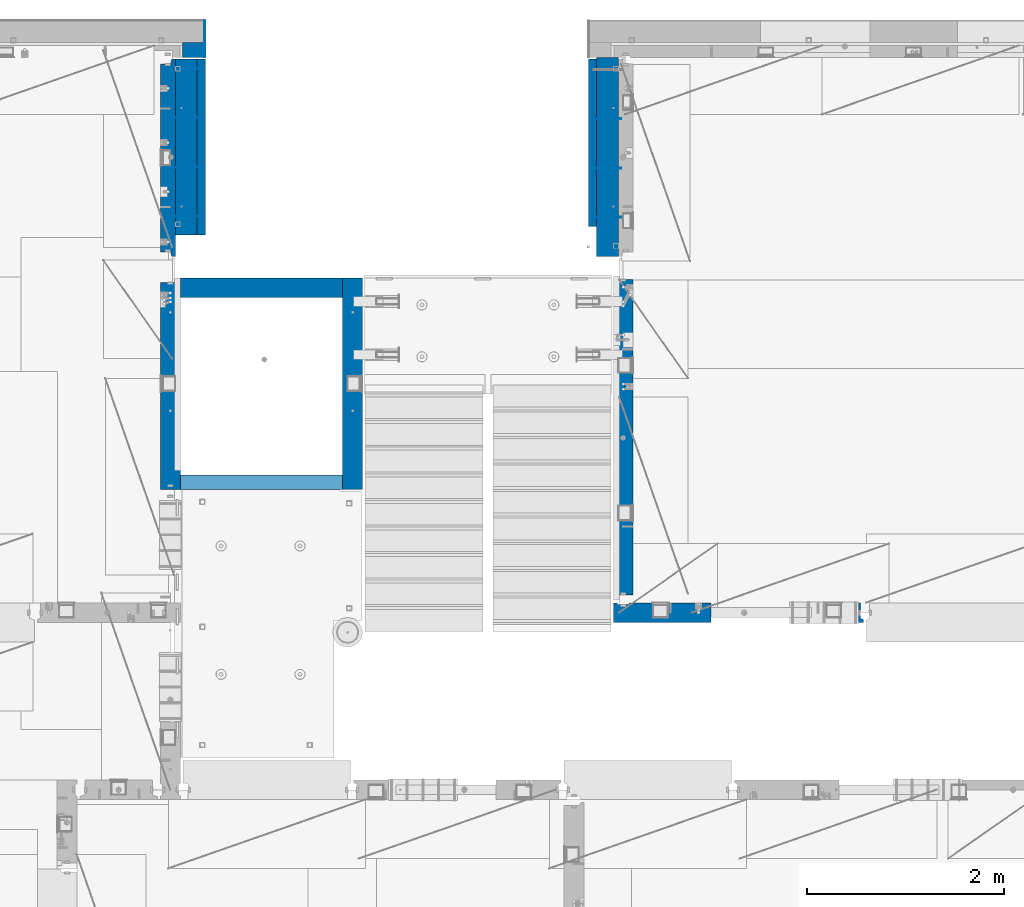
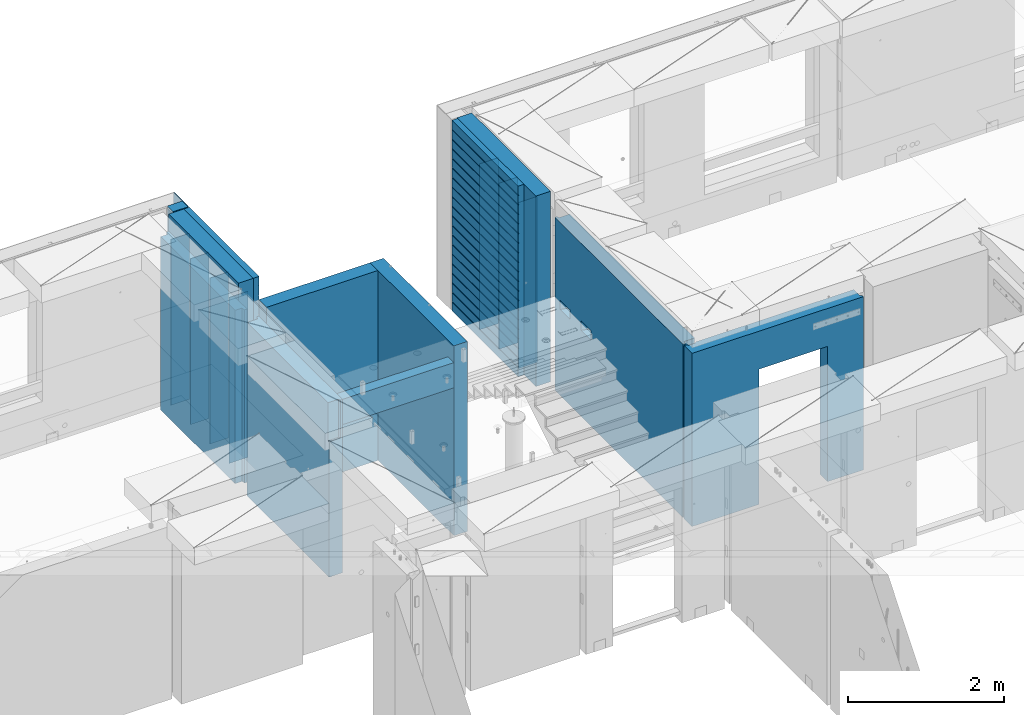
# One storey, part 227 of 334: 20 walls, 6 elements without a shape of their own.
"""IFC2X3 building model written with IfcOpenShell, lengths in millimetres."""

from ifc_helpers import new_model, si_unit, frame, origin_with_axes, place, context, subcontext, project, spatial, faceted_brep, material, type_object, element, aggregate, save


model = new_model("IFC2X3")

# Units and contexts
model_context = context("Model", 3, precision=1e-05, world=origin_with_axes())
body_context = subcontext(model_context, "Body", "Model", "MODEL_VIEW")
ifc_project = project(units=[si_unit("LENGTHUNIT", "METRE", prefix="MILLI"), si_unit("AREAUNIT", "SQUARE_METRE"), si_unit("VOLUMEUNIT", "CUBIC_METRE"), si_unit("MASSUNIT", "GRAM", prefix="KILO"), si_unit("TIMEUNIT", "SECOND"), si_unit("PLANEANGLEUNIT", "RADIAN"), si_unit("SOLIDANGLEUNIT", "STERADIAN"), si_unit("THERMODYNAMICTEMPERATUREUNIT", "DEGREE_CELSIUS"), si_unit("LUMINOUSINTENSITYUNIT", "LUMEN")], contexts=[model_context])

# Site, building, storey
site_placement = place(None, origin_with_axes())
site = spatial("IfcSite", under=ifc_project, at=site_placement, CompositionType="ELEMENT")
building_placement = place(site_placement, origin_with_axes())
building = spatial("IfcBuilding", under=site, at=building_placement, CompositionType="ELEMENT")
storey_placement = place(building_placement, origin_with_axes())
storey = spatial("IfcBuildingStorey", under=building, at=storey_placement, Name="3", CompositionType="ELEMENT", Elevation=0.0)

# Assembly, walls
assembly_1_placement = place(storey_placement, origin_with_axes())
assembly_1 = element("IfcElementAssembly", 1, at=assembly_1_placement, inside=storey, AssemblyPlace="NOTDEFINED", PredefinedType="REINFORCEMENT_UNIT")
ifc_material_1 = material(Name="Undefined")
wall_type_1 = type_object("IfcWallType", PredefinedType="NOTDEFINED")
wall_1_placement = place(assembly_1_placement, frame((22290.0, 21995.0, 89110.0), z_axis=(0.0, 0.0, 1.0), x_axis=(-1.0, 3.00000001838171e-08, 0.0)))
wall_1 = element("IfcWall", 2, at=wall_1_placement, type_object=wall_type_1, material=ifc_material_1, Name="(PD)", context=body_context, shape_type="Brep", body=[
    faceted_brep([(0.0, 5.0, -1300.0), (0.0, 5.0, 1300.0), (280.0, 5.0, 1300.0), (280.0, 5.0, -1300.0), (0.0, -5.0, 1300.0), (280.0, -5.0, 1300.0), (0.0, -5.0, -1300.0), (280.0, -5.0, -1300.0)], [[[0, 1, 2, 3]], [[1, 4, 5, 2]], [[4, 6, 7, 5]], [[6, 0, 3, 7]], [[5, 7, 3, 2]], [[6, 4, 1, 0]]]),
])
wall_2_placement = place(assembly_1_placement, frame((22290.0, 21495.0, 89110.0), z_axis=(0.0, 0.0, 1.0), x_axis=(-1.0, 3.00000001838171e-08, 0.0)))
wall_2 = element("IfcWall", 3, at=wall_2_placement, type_object=wall_type_1, material=ifc_material_1, Name="(PD)", context=body_context, shape_type="Brep", body=[
    faceted_brep([(0.0, 5.0, -1300.0), (0.0, 5.0, 1300.0), (280.0, 5.0, 1300.0), (280.0, 5.0, -1300.0), (0.0, -5.0, 1300.0), (280.0, -5.0, 1300.0), (0.0, -5.0, -1300.0), (280.0, -5.0, -1300.0)], [[[0, 1, 2, 3]], [[1, 4, 5, 2]], [[4, 6, 7, 5]], [[6, 0, 3, 7]], [[5, 7, 3, 2]], [[6, 4, 1, 0]]]),
])
wall_3_placement = place(assembly_1_placement, frame((22290.0, 20995.0, 89110.0), z_axis=(0.0, 0.0, 1.0), x_axis=(-1.0, 3.00000001838171e-08, 0.0)))
wall_3 = element("IfcWall", 4, at=wall_3_placement, type_object=wall_type_1, material=ifc_material_1, Name="(PD)", context=body_context, shape_type="Brep", body=[
    faceted_brep([(0.0, 5.0, -1300.0), (0.0, 5.0, 1300.0), (280.0, 5.0, 1300.0), (280.0, 5.0, -1300.0), (0.0, -5.0, 1300.0), (280.0, -5.0, 1300.0), (0.0, -5.0, -1300.0), (280.0, -5.0, -1300.0)], [[[0, 1, 2, 3]], [[1, 4, 5, 2]], [[4, 6, 7, 5]], [[6, 0, 3, 7]], [[5, 7, 3, 2]], [[6, 4, 1, 0]]]),
])

assembly_2_placement = place(storey_placement, origin_with_axes())
assembly_2 = element("IfcElementAssembly", 5, at=assembly_2_placement, inside=storey, Name="(PD)", AssemblyPlace="NOTDEFINED", PredefinedType="REINFORCEMENT_UNIT")
wall_4_placement = place(assembly_2_placement, frame((17730.0, 21005.0, 89115.0), z_axis=(0.0, 0.0, 1.0), x_axis=(1.0, 0.0, 0.0)))
wall_4 = element("IfcWall", 6, at=wall_4_placement, type_object=wall_type_1, material=ifc_material_1, Name="(PD)", context=body_context, shape_type="Brep", body=[
    faceted_brep([(0.0, 5.0, -1300.0), (0.0, 5.0, 1300.0), (280.0, 5.0, 1300.0), (280.0, 5.0, -1300.0), (0.0, -5.0, 1300.0), (280.0, -5.0, 1300.0), (0.0, -5.0, -1300.0), (280.0, -5.0, -1300.0)], [[[0, 1, 2, 3]], [[1, 4, 5, 2]], [[4, 6, 7, 5]], [[6, 0, 3, 7]], [[5, 7, 3, 2]], [[6, 4, 1, 0]]]),
])
wall_5_placement = place(assembly_2_placement, frame((17730.0, 21505.0, 89115.0), z_axis=(0.0, 0.0, 1.0), x_axis=(1.0, 0.0, 0.0)))
wall_5 = element("IfcWall", 7, at=wall_5_placement, type_object=wall_type_1, material=ifc_material_1, Name="(PD)", context=body_context, shape_type="Brep", body=[
    faceted_brep([(0.0, 5.0, -1300.0), (0.0, 5.0, 1300.0), (280.0, 5.0, 1300.0), (280.0, 5.0, -1300.0), (0.0, -5.0, 1300.0), (280.0, -5.0, 1300.0), (0.0, -5.0, -1300.0), (280.0, -5.0, -1300.0)], [[[0, 1, 2, 3]], [[1, 4, 5, 2]], [[4, 6, 7, 5]], [[6, 0, 3, 7]], [[5, 7, 3, 2]], [[6, 4, 1, 0]]]),
])
wall_6_placement = place(assembly_2_placement, frame((17730.0, 22005.0, 89115.0), z_axis=(0.0, 0.0, 1.0), x_axis=(1.0, 0.0, 0.0)))
wall_6 = element("IfcWall", 8, at=wall_6_placement, type_object=wall_type_1, material=ifc_material_1, Name="(PD)", context=body_context, shape_type="Brep", body=[
    faceted_brep([(0.0, 5.0, -1300.0), (0.0, 5.0, 1300.0), (280.0, 5.0, 1300.0), (280.0, 5.0, -1300.0), (0.0, -5.0, 1300.0), (280.0, -5.0, 1300.0), (0.0, -5.0, -1300.0), (280.0, -5.0, -1300.0)], [[[0, 1, 2, 3]], [[1, 4, 5, 2]], [[4, 6, 7, 5]], [[6, 0, 3, 7]], [[5, 7, 3, 2]], [[6, 4, 1, 0]]]),
])
wall_7_placement = place(assembly_2_placement, frame((17730.0, 22505.0, 89115.0), z_axis=(0.0, 0.0, 1.0), x_axis=(1.0, 0.0, 0.0)))
wall_7 = element("IfcWall", 9, at=wall_7_placement, type_object=wall_type_1, material=ifc_material_1, Name="(PD)", context=body_context, shape_type="Brep", body=[
    faceted_brep([(0.0, 5.0, -1300.0), (0.0, 5.0, 1300.0), (280.0, 5.0, 1300.0), (280.0, 5.0, -1300.0), (0.0, -5.0, 1300.0), (280.0, -5.0, 1300.0), (0.0, -5.0, -1300.0), (280.0, -5.0, -1300.0)], [[[0, 1, 2, 3]], [[1, 4, 5, 2]], [[4, 6, 7, 5]], [[6, 0, 3, 7]], [[5, 7, 3, 2]], [[6, 4, 1, 0]]]),
])

# Assembly, wall
assembly_3_placement = place(storey_placement, origin_with_axes())
assembly_3 = element("IfcElementAssembly", 10, at=assembly_3_placement, inside=storey, AssemblyPlace="NOTDEFINED", PredefinedType="REINFORCEMENT_UNIT")
ifc_material_2 = material(Name="CONCRETE/C25/30")
wall_type_2 = type_object("IfcWallType", PredefinedType="NOTDEFINED")
wall_8_placement = place(assembly_3_placement, frame((17710.0, 18214.9992663657, 89112.5), z_axis=(0.0, 0.0, 1.0), x_axis=(0.0, 1.0, 0.0)))
wall_8 = element("IfcWall", 11, at=wall_8_placement, type_object=wall_type_2, material=ifc_material_2, context=body_context, shape_type="Brep", body=[
    faceted_brep([(2120.00073363433, -57.0000000000036, 1357.5), (2120.00073363433, -57.0000000000036, -1357.5), (2120.00073363433, 100.0, -1357.5), (2120.00073363433, 100.0, 1357.5), (2165.00073363433, -70.0000000000036, 1357.5), (2165.00073363433, -70.0000000000036, -1357.5), (45.0, 100.0, 1357.5), (45.0, 100.0, 762.5), (45.0, -57.0, 762.5), (45.0, -57.0, 1357.5), (15.0, -70.0, 762.5), (15.0, 100.0, 762.5), (15.0, -70.0, 1357.5), (15.0, 100.0, -1357.5), (15.0, -100.0, -1357.5), (15.0, -100.0, 1357.5), (2165.00073363433, -100.0, -1357.5), (2165.00073363433, -100.0, 1357.5)], [[[0, 1, 2, 3]], [[4, 5, 1, 0]], [[6, 7, 8, 9]], [[10, 8, 7, 11]], [[12, 9, 8, 10]], [[11, 13, 14, 15, 12, 10]], [[15, 14, 16, 17]], [[3, 6, 9, 12, 15, 17, 4, 0]], [[13, 11, 7, 6, 3, 2]], [[16, 14, 13, 2, 1, 5]], [[17, 16, 5, 4]]]),
])

assembly_4_placement = place(storey_placement, origin_with_axes())
assembly_4 = element("IfcElementAssembly", 12, at=assembly_4_placement, inside=storey, AssemblyPlace="NOTDEFINED", PredefinedType="REINFORCEMENT_UNIT")
wall_9_placement = place(assembly_4_placement, frame((22310.0, 16980.0, 89112.5), z_axis=(0.0, 0.0, 1.0), x_axis=(1.0, 0.0, 0.0)))
wall_9 = element("IfcWall", 13, at=wall_9_placement, type_object=wall_type_2, material=ifc_material_2, context=body_context, shape_type="Brep", body=[
    faceted_brep([(890.000686645508, 100.0, 762.5), (890.000686645508, -100.0, 762.5), (890.000686645508, -100.0, -1357.5), (890.000686645508, 100.0, -1357.5), (1910.00068664551, 100.0, 762.5), (1910.00068664551, -100.0, 762.5), (1910.00068664551, 100.0, -1357.5), (1910.00068664551, -100.0, -1357.5), (-100.0, -100.0, -1357.5), (-100.0, -100.0, 1357.5), (-100.0, 100.0, 1357.5), (-100.0, 100.0, -1357.5), (2440.0, -100.0, 1357.5), (2440.0, -100.0, -1357.5), (2440.0, -70.0000000000036, -1357.5), (2440.0, -70.0000000000036, 1357.5), (2410.0, 100.0, 1357.5), (2410.0, -57.0, 1357.5), (2410.0, -57.0, -1357.5), (2410.0, 100.0, -1357.5), (65.0000000000036, 100.0, 1357.5), (52.0, 80.0, 1357.5), (-52.0, 80.0, 1357.5), (-65.0, 100.0, 1357.5), (-65.0, 100.0, -1357.5), (-52.0, 80.0, -1357.5), (52.0, 80.0, -1357.5), (65.0000000000036, 100.0, -1357.5)], [[[0, 1, 2, 3]], [[4, 5, 1, 0]], [[6, 7, 5, 4]], [[8, 9, 10, 11]], [[12, 13, 14, 15]], [[16, 17, 18, 19]], [[15, 14, 18, 17]], [[16, 20, 21, 22, 23, 10, 9, 12, 15, 17]], [[11, 10, 23, 24]], [[22, 25, 24, 23]], [[21, 26, 25, 22]], [[20, 27, 26, 21]], [[8, 11, 24, 25, 26, 27, 3, 2]], [[13, 12, 9, 8, 2, 1, 5, 7]], [[19, 18, 14, 13, 7, 6]], [[3, 27, 20, 16, 19, 6, 4, 0]]]),
])
aggregate(assembly_4, [wall_9])

assembly_5_placement = place(storey_placement, origin_with_axes())
assembly_5 = element("IfcElementAssembly", 14, at=assembly_5_placement, inside=storey, AssemblyPlace="NOTDEFINED", PredefinedType="REINFORCEMENT_UNIT")
wall_10_placement = place(assembly_5_placement, frame((22310.0, 16980.0, 89112.5), z_axis=(0.0, 0.0, 1.0), x_axis=(0.0, 1.0, 0.0)))
wall_10 = element("IfcWall", 15, at=wall_10_placement, type_object=wall_type_2, material=ifc_material_2, context=body_context, shape_type="Brep", body=[
    faceted_brep([(3059.9952678883, 0.0998642726626713, 102.5), (3259.9952678883, 0.0998642726626713, 102.5), (3259.9952678883, 0.0998642726626713, -7.5), (3059.9952678883, 0.0998642726626713, -7.5), (3034.9952678883, 100.099864272663, -7.5), (3284.9952678883, 100.099864272663, -7.5), (3034.9952678883, 100.099864272663, 137.5), (3284.9952678883, 100.099864272663, 137.5), (3420.0, 70.0, 1357.5), (3420.0, 100.0, 1357.5), (130.0, 100.0, 1357.5), (130.0, 70.0, 1357.5), (180.0, 57.0, 1357.5), (180.0, -100.0, 1357.5), (3384.99999178648, -100.000000948603, 1357.5), (3385.00000172571, 57.0000007519884, 1357.5), (130.0, 100.0, -1357.5), (130.0, 70.0, -1357.5), (180.0, 57.0, -1357.5), (180.0, -100.0, -1357.5), (3384.99999178648, -100.0, -1357.5), (3385.00000172571, 57.0000007519884, -1357.5), (3420.0, 100.0, -1357.5), (3420.0, 70.0, -1357.5), (2519.9952678883, 0.0998642726626713, 102.5), (2719.9952678883, 0.0998642726626713, 102.5), (2719.9952678883, 0.0998642726626713, -7.5), (2519.9952678883, 0.0998642726626713, -7.5), (2744.9952678883, 100.099864272663, -7.5), (2744.9952678883, 100.099864272663, 137.5), (2494.9952678883, 100.099864272663, -7.5), (2494.9952678883, 100.099864272663, 137.5)], [[[0, 1, 2, 3]], [[4, 3, 2, 5]], [[6, 0, 3, 4]], [[7, 1, 0, 6]], [[5, 2, 1, 7]], [[8, 9, 10, 11, 12, 13, 14, 15]], [[10, 16, 17, 11]], [[11, 17, 18, 12]], [[13, 12, 18, 19]], [[13, 19, 20, 14]], [[14, 20, 21, 15]], [[19, 18, 17, 16, 22, 23, 21, 20]], [[15, 21, 23, 8]], [[22, 9, 8, 23]], [[24, 25, 26, 27]], [[28, 26, 25, 29]], [[30, 27, 26, 28]], [[31, 24, 27, 30]], [[29, 25, 24, 31]], [[16, 10, 9, 22], [4, 5, 7, 6], [30, 28, 29, 31]]]),
])
aggregate(assembly_5, [wall_10])

# Wall
ifc_material_3 = material(Name="COS5gt")
wall_type_3 = type_object("IfcWallType", PredefinedType="NOTDEFINED")
wall_11_placement = place(assembly_1_placement, frame((22150.0, 20595.0, 89247.5), z_axis=(0.0, 0.0, 1.0), x_axis=(0.0, 1.0, 0.0)))
wall_11 = element("IfcWall", 16, at=wall_11_placement, type_object=wall_type_3, material=ifc_material_3, context=body_context, shape_type="Brep", body=[
    faceted_brep([(0.0, 110.0, -1492.5), (0.0, 110.0, 1492.5), (2025.0, 110.0, 1492.5), (2025.0, 110.0, -1492.5), (0.0, -110.0, 1492.5), (2025.0, -110.0, 1492.5), (0.0, -110.0, -1492.5), (2025.0, -110.0, -1492.5)], [[[0, 1, 2, 3]], [[1, 4, 5, 2]], [[4, 6, 7, 5]], [[6, 0, 3, 7]], [[5, 7, 3, 2]], [[6, 4, 1, 0]]]),
])

# Assembly, wall
assembly_6_placement = place(storey_placement, origin_with_axes())
assembly_6 = element("IfcElementAssembly", 17, at=assembly_6_placement, inside=storey, AssemblyPlace="NOTDEFINED", PredefinedType="REINFORCEMENT_UNIT")
ifc_material_4 = material()
wall_12_placement = place(assembly_6_placement, frame((17945.0, 22770.0, 89247.5), z_axis=(0.0, 0.0, 1.0), x_axis=(0.0, -1.0, 0.0)))
wall_12 = element("IfcWall", 18, at=wall_12_placement, type_object=wall_type_3, material=ifc_material_4, context=body_context, shape_type="Brep", body=[
    faceted_brep([(0.0, 110.0, -1492.5), (0.0, 110.0, 1492.5), (150.0, 110.0, 1492.5), (150.0, 110.0, -1492.5), (0.0, -110.0, 1492.5), (150.0, -110.0, 1492.5), (0.0, -110.0, -1492.5), (150.0, -110.0, -1492.5)], [[[0, 1, 2, 3]], [[1, 4, 5, 2]], [[4, 6, 7, 5]], [[6, 0, 3, 7]], [[5, 7, 3, 2]], [[6, 4, 1, 0]]]),
])

# Wall
wall_13_placement = place(assembly_2_placement, frame((17870.0, 22605.0, 89247.5), z_axis=(0.0, 0.0, 1.0), x_axis=(0.0, -1.0, 0.0)))
wall_13 = element("IfcWall", 19, at=wall_13_placement, type_object=wall_type_3, material=ifc_material_3, context=body_context, shape_type="Brep", body=[
    faceted_brep([(0.0, 110.0, -1492.5), (0.0, 110.0, 1492.5), (1790.0, 110.0, 1492.5), (1790.0, 110.0, -1492.5), (0.0, -110.0, 1492.5), (1790.0, -110.0, 1492.5), (0.0, -110.0, -1492.5), (1790.0, -110.0, -1492.5)], [[[0, 1, 2, 3]], [[1, 4, 5, 2]], [[4, 6, 7, 5]], [[6, 0, 3, 7]], [[5, 7, 3, 2]], [[6, 4, 1, 0]]]),
])

ifc_material_5 = material(Name="CONCRETE/C30/37")
wall_type_4 = type_object("IfcWallType", PredefinedType="NOTDEFINED")
wall_14_placement = place(assembly_1_placement, frame((21997.5, 20900.0, 89247.5), z_axis=(0.0, 0.0, 1.0), x_axis=(0.0, 1.0, 0.0)))
wall_14 = element("IfcWall", 20, at=wall_14_placement, type_object=wall_type_4, material=ifc_material_5, context=body_context, shape_type="Brep", body=[
    faceted_brep([(1705.0, 42.5, -1357.0), (0.0, 42.5, -1357.00000005524), (0.0, 32.4999992507037, -1355.00000000074), (1705.0, 32.5, -1355.0), (1705.0, 32.5, -1345.0), (0.0, 32.4999991127006, -1344.99999959956), (0.0, 42.5, -1343.00000011075), (1705.0, 42.5, -1343.0), (0.0, -42.5, -1492.5), (0.0, 42.5, -1492.5), (1705.0, 42.5, -1492.5), (1705.0, -42.5, -1492.5), (0.0, -42.5, 1492.5), (1705.0, -42.5, 1492.5), (0.0, 42.5, 1492.5), (1705.0, 42.5, 1492.5), (1705.0, 42.5, 1357.0), (0.0, 42.5, 1356.99999988925), (1705.0, 32.5, 1355.0), (-3.63797880709171e-12, 32.4999991127006, 1355.00000040044), (1705.0, 32.5, 1345.0), (-3.63797880709171e-12, 32.4999992507037, 1344.99999999926), (1705.0, 42.5, 1343.0), (0.0, 42.5, 1342.99999994476), (1705.0, 42.5, 1207.0), (0.0, 42.5, 1206.99999988925), (1705.0, 32.5, 1205.0), (0.0, 32.4999991127006, 1205.00000040044), (1705.0, 32.5, 1195.0), (0.0, 32.4999992507037, 1194.99999999926), (1705.0, 42.5, 1193.0), (0.0, 42.5, 1192.99999994476), (1705.0, 42.5, 1057.0), (0.0, 42.5, 1056.99999988925), (1705.0, 32.5, 1055.0), (0.0, 32.4999991127006, 1055.00000040044), (1705.0, 32.5, 1045.0), (0.0, 32.4999992507037, 1044.99999999926), (1705.0, 42.5, 1043.0), (0.0, 42.5, 1042.99999994476), (1705.0, 42.5, 907.0), (0.0, 42.5, 906.999999889245), (1705.0, 32.5, 905.0), (0.0, 32.4999991127006, 905.00000040044), (1705.0, 32.5, 895.0), (0.0, 32.4999992507037, 894.999999999258), (1705.0, 42.5, 893.0), (0.0, 42.5, 892.999999944761), (1705.0, 42.5, 757.0), (0.0, 42.5, 756.999999889245), (1705.0, 32.5, 755.0), (0.0, 32.4999991127006, 755.00000040044), (1705.0, 32.5, 745.0), (0.0, 32.4999992507037, 744.999999999258), (1705.0, 42.5, 743.0), (0.0, 42.5, 742.999999944761), (1705.0, 42.5, 607.0), (0.0, 42.5, 606.999999889245), (1705.0, 32.5, 605.0), (3.63797880709171e-12, 32.4999991127006, 605.00000040044), (1705.0, 32.5, 595.0), (3.63797880709171e-12, 32.4999992507037, 594.999999999258), (1705.0, 42.5, 593.0), (0.0, 42.5, 592.999999944761), (1705.0, 42.5, 457.0), (0.0, 42.5, 456.999999889245), (1705.0, 32.5, 455.0), (0.0, 32.4999991127006, 455.00000040044), (1705.0, 32.5, 445.0), (0.0, 32.4999992507037, 444.999999999258), (1705.0, 42.5, 443.0), (0.0, 42.5, 442.999999944761), (1705.0, 42.5, 307.0), (0.0, 42.5, 306.999999889245), (1705.0, 32.5, 305.0), (-3.63797880709171e-12, 32.4999991127006, 305.00000040044), (1705.0, 32.5, 295.0), (-3.63797880709171e-12, 32.4999992507037, 294.999999999258), (1705.0, 42.5, 293.0), (0.0, 42.5, 292.999999944761), (1705.0, 42.5, 157.0), (0.0, 42.5, 156.999999889245), (1705.0, 32.5, 155.0), (-3.63797880709171e-12, 32.4999991127006, 155.00000040044), (1705.0, 32.5, 145.0), (-3.63797880709171e-12, 32.4999992507037, 144.999999999258), (1705.0, 42.5, 143.0), (0.0, 42.5, 142.999999944761), (1705.0, 42.5, 7.0), (0.0, 42.5, 6.99999988924537), (1705.0, 32.5, 5.0), (0.0, 32.4999991127006, 5.0000004004396), (1705.0, 32.5, -5.0), (0.0, 32.4999992507037, -5.00000000074215), (1705.0, 42.5, -7.0), (0.0, 42.5, -7.00000005523907), (1705.0, 42.5, -143.0), (0.0, 42.5, -143.000000110755), (1705.0, 32.5, -145.0), (3.63797880709171e-12, 32.4999991127006, -144.99999959956), (1705.0, 32.5, -155.0), (3.63797880709171e-12, 32.4999992507037, -155.000000000742), (1705.0, 42.5, -157.0), (0.0, 42.5, -157.000000055239), (1705.0, 42.5, -293.0), (0.0, 42.5, -293.000000110755), (1705.0, 32.5, -295.0), (0.0, 32.4999991127006, -294.99999959956), (1705.0, 32.5, -305.0), (0.0, 32.4999992507037, -305.000000000742), (1705.0, 42.5, -307.0), (0.0, 42.5, -307.000000055239), (1705.0, 42.5, -443.0), (0.0, 42.5, -443.000000110755), (1705.0, 32.5, -445.0), (0.0, 32.4999991127006, -444.99999959956), (1705.0, 32.5, -455.0), (0.0, 32.4999992507037, -455.000000000742), (1705.0, 42.5, -457.0), (0.0, 42.5, -457.000000055239), (1705.0, 42.5, -593.0), (0.0, 42.5, -593.000000110755), (1705.0, 32.5, -595.0), (3.63797880709171e-12, 32.4999991127006, -594.99999959956), (1705.0, 32.5, -605.0), (3.63797880709171e-12, 32.4999992507037, -605.000000000742), (1705.0, 42.5, -607.0), (0.0, 42.5, -607.000000055239), (1705.0, 42.5, -743.0), (0.0, 42.5, -743.000000110755), (1705.0, 32.5, -745.0), (0.0, 32.4999991127006, -744.99999959956), (1705.0, 32.5, -755.0), (0.0, 32.4999992507037, -755.000000000742), (1705.0, 42.5, -757.0), (0.0, 42.5, -757.000000055239), (1705.0, 42.5, -893.0), (0.0, 42.5, -893.000000110755), (1705.0, 32.5, -895.0), (0.0, 32.4999991127006, -894.99999959956), (1705.0, 32.5, -905.0), (0.0, 32.4999992507037, -905.000000000742), (1705.0, 42.5, -907.0), (0.0, 42.5, -907.000000055239), (1705.0, 42.5, -1043.0), (0.0, 42.5, -1043.00000011075), (1705.0, 32.5, -1045.0), (0.0, 32.4999991127006, -1044.99999959956), (1705.0, 32.5, -1055.0), (0.0, 32.4999992507037, -1055.00000000074), (1705.0, 42.5, -1057.0), (0.0, 42.5, -1057.00000005524), (1705.0, 42.5, -1193.0), (0.0, 42.5, -1193.00000011075), (1705.0, 32.5, -1195.0), (0.0, 32.4999991127006, -1194.99999959956), (1705.0, 32.5, -1205.0), (0.0, 32.4999992507037, -1205.00000000074), (1705.0, 42.5, -1207.0), (0.0, 42.5, -1207.00000005524)], [[[0, 1, 2, 3]], [[4, 5, 6, 7]], [[3, 2, 5, 4]], [[8, 9, 10, 11]], [[12, 8, 11, 13]], [[14, 12, 13, 15]], [[14, 15, 16, 17]], [[18, 19, 17, 16]], [[20, 21, 19, 18]], [[22, 23, 21, 20]], [[24, 25, 23, 22]], [[26, 27, 25, 24]], [[28, 29, 27, 26]], [[30, 31, 29, 28]], [[32, 33, 31, 30]], [[34, 35, 33, 32]], [[36, 37, 35, 34]], [[38, 39, 37, 36]], [[40, 41, 39, 38]], [[42, 43, 41, 40]], [[44, 45, 43, 42]], [[46, 47, 45, 44]], [[48, 49, 47, 46]], [[50, 51, 49, 48]], [[52, 53, 51, 50]], [[54, 55, 53, 52]], [[56, 57, 55, 54]], [[58, 59, 57, 56]], [[60, 61, 59, 58]], [[62, 63, 61, 60]], [[64, 65, 63, 62]], [[66, 67, 65, 64]], [[68, 69, 67, 66]], [[70, 71, 69, 68]], [[72, 73, 71, 70]], [[74, 75, 73, 72]], [[76, 77, 75, 74]], [[78, 79, 77, 76]], [[80, 81, 79, 78]], [[82, 83, 81, 80]], [[84, 85, 83, 82]], [[86, 87, 85, 84]], [[88, 89, 87, 86]], [[90, 91, 89, 88]], [[92, 93, 91, 90]], [[94, 95, 93, 92]], [[96, 97, 95, 94]], [[98, 99, 97, 96]], [[100, 101, 99, 98]], [[102, 103, 101, 100]], [[104, 105, 103, 102]], [[106, 107, 105, 104]], [[108, 109, 107, 106]], [[110, 111, 109, 108]], [[112, 113, 111, 110]], [[114, 115, 113, 112]], [[116, 117, 115, 114]], [[118, 119, 117, 116]], [[120, 121, 119, 118]], [[122, 123, 121, 120]], [[124, 125, 123, 122]], [[126, 127, 125, 124]], [[128, 129, 127, 126]], [[130, 131, 129, 128]], [[132, 133, 131, 130]], [[134, 135, 133, 132]], [[136, 137, 135, 134]], [[138, 139, 137, 136]], [[140, 141, 139, 138]], [[142, 143, 141, 140]], [[144, 145, 143, 142]], [[146, 147, 145, 144]], [[148, 149, 147, 146]], [[150, 151, 149, 148]], [[152, 153, 151, 150]], [[154, 155, 153, 152]], [[156, 157, 155, 154]], [[158, 159, 157, 156]], [[7, 6, 159, 158]], [[21, 23, 25, 27, 29, 31, 33, 35, 37, 39, 41, 43, 45, 47, 49, 51, 53, 55, 57, 59, 61, 63, 65, 67, 69, 71, 73, 75, 77, 79, 81, 83, 85, 87, 89, 91, 93, 95, 97, 99, 101, 103, 105, 107, 109, 111, 113, 115, 117, 119, 121, 123, 125, 127, 129, 131, 133, 135, 137, 139, 141, 143, 145, 147, 149, 151, 153, 155, 157, 159, 6, 5, 2, 1, 9, 8, 12, 14, 17, 19]], [[10, 9, 1, 0]], [[15, 13, 11, 10, 0, 3, 4, 7, 158, 156, 154, 152, 150, 148, 146, 144, 142, 140, 138, 136, 134, 132, 130, 128, 126, 124, 122, 120, 118, 116, 114, 112, 110, 108, 106, 104, 102, 100, 98, 96, 94, 92, 90, 88, 86, 84, 82, 80, 78, 76, 74, 72, 70, 68, 66, 64, 62, 60, 58, 56, 54, 52, 50, 48, 46, 44, 42, 40, 38, 36, 34, 32, 30, 28, 26, 24, 22, 20, 18, 16]]]),
])

aggregate(assembly_1, [wall_11, wall_1, wall_2, wall_3, wall_14])

wall_15_placement = place(assembly_2_placement, frame((18022.5, 22620.0, 89247.5), z_axis=(0.0, 0.0, 1.0), x_axis=(0.0, -1.0, 0.0)))
wall_15 = element("IfcWall", 21, at=wall_15_placement, type_object=wall_type_4, material=ifc_material_5, context=body_context, shape_type="Brep", body=[
    faceted_brep([(15.0, 42.5, 1342.99999994476), (15.0, 32.4999992506928, 1344.9999999992), (1805.0, 32.5, 1345.0), (1805.0, 42.5, 1343.0), (15.0, 32.4999991126933, 1355.00000040043), (1805.0, 32.5, 1355.0), (15.0, 42.5, 1356.99999988925), (1805.0, 42.5, 1357.0), (15.0, 42.5, 1206.99999988925), (1805.0, 42.5, 1207.0), (1805.0, 32.5, 1205.0), (15.0000000000009, 32.4999991126933, 1205.00000040043), (1805.0, 32.5, 1195.0), (15.0000000000009, 32.4999992506928, 1194.9999999992), (15.0, 42.5, 1192.99999994476), (1805.0, 42.5, 1193.0), (1805.0, 42.5, 1057.0), (15.0, 42.5, 1056.99999988925), (1805.0, 32.5, 1055.0), (15.0, 32.4999991126933, 1055.00000040043), (1805.0, 32.5, 1045.0), (15.0, 32.4999992506928, 1044.9999999992), (15.0, 42.5, 1042.99999994476), (1805.0, 42.5, 1043.0), (1805.0, 42.5, 907.0), (15.0, 42.5, 906.999999889245), (1805.0, 32.5, 905.0), (15.0, 32.4999991126933, 905.000000400425), (1805.0, 32.5, 895.0), (15.0, 32.4999992506928, 894.9999999992), (15.0, 42.5, 892.999999944761), (1805.0, 42.5, 893.0), (1805.0, 42.5, 757.0), (15.0, 42.5, 756.999999889245), (1805.0, 32.5, 755.0), (15.0, 32.4999991126933, 755.000000400425), (1805.0, 32.5, 745.0), (15.0, 32.4999992506928, 744.9999999992), (15.0, 42.5, 742.999999944761), (1805.0, 42.5, 743.0), (1805.0, 42.5, 607.0), (15.0, 42.5, 606.999999889245), (1805.0, 32.5, 605.0), (15.0, 32.4999991126933, 605.000000400425), (1805.0, 32.5, 595.0), (15.0, 32.4999992506928, 594.9999999992), (15.0, 42.5, 592.999999944761), (1805.0, 42.5, 593.0), (1805.0, 42.5, 457.0), (15.0, 42.5, 456.999999889245), (1805.0, 32.5, 455.0), (15.0, 32.4999991126933, 455.000000400425), (1805.0, 32.5, 445.0), (15.0, 32.4999992506928, 444.9999999992), (15.0, 42.5, 442.999999944761), (1805.0, 42.5, 443.0), (1805.0, 42.5, 307.0), (15.0, 42.5, 306.999999889245), (1805.0, 32.5, 305.0), (15.0, 32.4999991126933, 305.000000400425), (1805.0, 32.5, 295.0), (15.0, 32.4999992506928, 294.9999999992), (15.0, 42.5, 292.999999944761), (1805.0, 42.5, 293.0), (1805.0, 42.5, 157.0), (15.0, 42.5, 156.999999889245), (1805.0, 32.5, 155.0), (15.0000000000009, 32.4999991126933, 155.000000400425), (1805.0, 32.5, 145.0), (15.0000000000009, 32.4999992506928, 144.9999999992), (15.0, 42.5, 142.999999944761), (1805.0, 42.5, 143.0), (1805.0, 42.5, 7.0), (15.0, 42.5, 6.99999988924537), (1805.0, 32.5, 5.0), (14.9999999999991, 32.4999991126933, 5.00000040042505), (1805.0, 32.5, -5.0), (14.9999999999991, 32.4999992506928, -5.00000000080036), (15.0, 42.5, -7.00000005523907), (1805.0, 42.5, -7.0), (1805.0, 42.5, -143.0), (15.0, 42.5, -143.000000110755), (1805.0, 32.5, -145.0), (15.0000000000009, 32.4999991126933, -144.999999599575), (1805.0, 32.5, -155.0), (15.0000000000009, 32.4999992506928, -155.0000000008), (15.0, 42.5, -157.000000055239), (1805.0, 42.5, -157.0), (1805.0, 42.5, -293.0), (15.0, 42.5, -293.000000110755), (1805.0, 32.5, -295.0), (15.0, 32.4999991126933, -294.999999599575), (1805.0, 32.5, -305.0), (15.0, 32.4999992506928, -305.0000000008), (15.0, 42.5, -307.000000055239), (1805.0, 42.5, -307.0), (1805.0, 42.5, -443.0), (15.0, 42.5, -443.000000110755), (1805.0, 32.5, -445.0), (15.0000000000009, 32.4999991126933, -444.999999599575), (1805.0, 32.5, -455.0), (15.0000000000009, 32.4999992506928, -455.0000000008), (15.0, 42.5, -457.000000055239), (1805.0, 42.5, -457.0), (1805.0, 42.5, -593.0), (15.0, 42.5, -593.000000110755), (1805.0, 32.5, -595.0), (15.0, 32.4999991126933, -594.999999599575), (1805.0, 32.5, -605.0), (15.0, 32.4999992506928, -605.0000000008), (15.0, 42.5, -607.000000055239), (1805.0, 42.5, -607.0), (1805.0, 42.5, -743.0), (15.0, 42.5, -743.000000110755), (1805.0, 32.5, -745.0), (15.0, 32.4999991126933, -744.999999599575), (1805.0, 32.5, -755.0), (15.0, 32.4999992506928, -755.0000000008), (15.0, 42.5, -757.000000055239), (1805.0, 42.5, -757.0), (1805.0, 42.5, -893.0), (15.0, 42.5, -893.000000110755), (1805.0, 32.5, -895.0), (15.0000000000009, 32.4999991126933, -894.999999599575), (1805.0, 32.5, -905.0), (15.0000000000009, 32.4999992506928, -905.0000000008), (15.0, 42.5, -907.000000055239), (1805.0, 42.5, -907.0), (1805.0, 42.5, -1043.0), (15.0, 42.5, -1043.00000011075), (1805.0, 32.5, -1045.0), (15.0, 32.4999991126933, -1044.99999959957), (1805.0, 32.5, -1055.0), (15.0, 32.4999992506928, -1055.0000000008), (15.0, 42.5, -1057.00000005524), (1805.0, 42.5, -1057.0), (1805.0, 42.5, -1193.0), (15.0, 42.5, -1193.00000011075), (1805.0, 32.5, -1195.0), (15.0, 32.4999991126933, -1194.99999959957), (1805.0, 32.5, -1205.0), (15.0, 32.4999992506928, -1205.0000000008), (15.0, 42.5, -1207.00000005524), (1805.0, 42.5, -1207.0), (1805.0, 42.5, -1343.0), (15.0, 42.5, -1343.00000011075), (1805.0, 32.5, -1345.0), (15.0, 32.4999991126933, -1344.99999959957), (1805.0, 32.5, -1355.0), (15.0, 32.4999992506928, -1355.0000000008), (15.0, 42.5, -1357.00000005524), (1805.0, 42.5, -1357.0), (1805.0, 42.5, -1492.5), (15.0, 42.5, -1492.5), (15.0, -42.5, -1492.5), (1805.0, -42.5, -1492.5), (15.0, -42.5, 1492.5), (1805.0, -42.5, 1492.5), (15.0, 42.5, 1492.5), (1805.0, 42.5, 1492.5)], [[[0, 1, 2, 3]], [[4, 5, 2, 1]], [[6, 7, 5, 4]], [[8, 9, 10, 11]], [[11, 10, 12, 13]], [[14, 13, 12, 15]], [[16, 17, 14, 15]], [[17, 16, 18, 19]], [[19, 18, 20, 21]], [[22, 21, 20, 23]], [[24, 25, 22, 23]], [[25, 24, 26, 27]], [[27, 26, 28, 29]], [[30, 29, 28, 31]], [[32, 33, 30, 31]], [[33, 32, 34, 35]], [[35, 34, 36, 37]], [[38, 37, 36, 39]], [[40, 41, 38, 39]], [[41, 40, 42, 43]], [[43, 42, 44, 45]], [[46, 45, 44, 47]], [[48, 49, 46, 47]], [[49, 48, 50, 51]], [[51, 50, 52, 53]], [[54, 53, 52, 55]], [[56, 57, 54, 55]], [[57, 56, 58, 59]], [[59, 58, 60, 61]], [[62, 61, 60, 63]], [[64, 65, 62, 63]], [[65, 64, 66, 67]], [[67, 66, 68, 69]], [[70, 69, 68, 71]], [[72, 73, 70, 71]], [[73, 72, 74, 75]], [[75, 74, 76, 77]], [[78, 77, 76, 79]], [[80, 81, 78, 79]], [[81, 80, 82, 83]], [[83, 82, 84, 85]], [[86, 85, 84, 87]], [[88, 89, 86, 87]], [[89, 88, 90, 91]], [[91, 90, 92, 93]], [[94, 93, 92, 95]], [[96, 97, 94, 95]], [[97, 96, 98, 99]], [[99, 98, 100, 101]], [[102, 101, 100, 103]], [[104, 105, 102, 103]], [[105, 104, 106, 107]], [[107, 106, 108, 109]], [[110, 109, 108, 111]], [[112, 113, 110, 111]], [[113, 112, 114, 115]], [[115, 114, 116, 117]], [[118, 117, 116, 119]], [[120, 121, 118, 119]], [[121, 120, 122, 123]], [[123, 122, 124, 125]], [[126, 125, 124, 127]], [[128, 129, 126, 127]], [[129, 128, 130, 131]], [[131, 130, 132, 133]], [[134, 133, 132, 135]], [[136, 137, 134, 135]], [[137, 136, 138, 139]], [[139, 138, 140, 141]], [[142, 141, 140, 143]], [[144, 145, 142, 143]], [[145, 144, 146, 147]], [[147, 146, 148, 149]], [[150, 149, 148, 151]], [[152, 153, 150, 151]], [[154, 153, 152, 155]], [[156, 154, 155, 157]], [[158, 156, 157, 159]], [[1, 0, 8, 11, 13, 14, 17, 19, 21, 22, 25, 27, 29, 30, 33, 35, 37, 38, 41, 43, 45, 46, 49, 51, 53, 54, 57, 59, 61, 62, 65, 67, 69, 70, 73, 75, 77, 78, 81, 83, 85, 86, 89, 91, 93, 94, 97, 99, 101, 102, 105, 107, 109, 110, 113, 115, 117, 118, 121, 123, 125, 126, 129, 131, 133, 134, 137, 139, 141, 142, 145, 147, 149, 150, 153, 154, 156, 158, 6, 4]], [[9, 8, 0, 3]], [[159, 157, 155, 152, 151, 148, 146, 144, 143, 140, 138, 136, 135, 132, 130, 128, 127, 124, 122, 120, 119, 116, 114, 112, 111, 108, 106, 104, 103, 100, 98, 96, 95, 92, 90, 88, 87, 84, 82, 80, 79, 76, 74, 72, 71, 68, 66, 64, 63, 60, 58, 56, 55, 52, 50, 48, 47, 44, 42, 40, 39, 36, 34, 32, 31, 28, 26, 24, 23, 20, 18, 16, 15, 12, 10, 9, 3, 2, 5, 7]], [[158, 159, 7, 6]]]),
])

wall_type_5 = type_object("IfcWallType", PredefinedType="NOTDEFINED")
wall_16_placement = place(assembly_2_placement, frame((17685.0, 22605.0, 89112.5), z_axis=(0.0, 0.0, 1.0), x_axis=(0.0, -1.0, 0.0)))
wall_16 = element("IfcWall", 22, at=wall_16_placement, type_object=wall_type_5, material=ifc_material_2, context=body_context, shape_type="Brep", body=[
    faceted_brep([(1959.99999772087, -75.0, 1357.5), (1959.99999772087, -75.0, -1357.5), (1959.99999772087, 27.0, -1357.5), (1959.99999772087, 27.0, 1357.5), (2009.99999772087, 40.0, -1357.5), (2009.99999772087, 40.0, 1357.5), (50.0, -75.0, 1357.5), (50.0, 27.0, 1357.5), (50.0, 27.0, -1357.5), (50.0, -75.0, -1357.5), (0.0, 40.0, 1357.5), (0.0, 40.0, -1357.5), (0.0, 75.0, 1357.5), (0.0, 75.0, -1357.5), (2009.99999772087, 75.0, 1357.5), (2009.99999772087, 75.0, -1357.5)], [[[0, 1, 2, 3]], [[3, 2, 4, 5]], [[6, 7, 8, 9]], [[10, 11, 8, 7]], [[12, 13, 11, 10]], [[13, 12, 14, 15]], [[15, 14, 5, 4]], [[11, 13, 15, 4, 2, 1, 9, 8]], [[1, 0, 6, 9]], [[0, 3, 5, 14, 12, 10, 7, 6]]]),
])

aggregate(assembly_2, [wall_13, wall_4, wall_5, wall_6, wall_16, wall_7, wall_15])

wall_type_6 = type_object("IfcWallType", PredefinedType="NOTDEFINED")
wall_17_placement = place(assembly_3_placement, frame((17809.9999105288, 20280.0000293051, 89242.5), z_axis=(0.0, 0.0, 1.0), x_axis=(1.0, 0.0, 0.0)))
wall_17 = element("IfcWall", 23, at=wall_17_placement, type_object=wall_type_6, material=ifc_material_2, context=body_context, shape_type="Brep", body=[
    faceted_brep([(0.0, 100.0, -1487.5), (0.0, 100.0, 1487.5), (1649.99977111816, 100.0, 1487.5), (1649.99977111816, 100.0, -1487.5), (0.0, -100.0, 1487.5), (1649.99977111816, -100.0, 1487.5), (0.0, -100.0, -1487.5), (1649.99977111816, -100.0, -1487.5)], [[[0, 1, 2, 3]], [[1, 4, 5, 2]], [[4, 6, 7, 5]], [[6, 0, 3, 7]], [[5, 7, 3, 2]], [[6, 4, 1, 0]]]),
])

wall_18_placement = place(assembly_3_placement, frame((19559.999681647, 18229.9992663657, 89242.5), z_axis=(0.0, 0.0, 1.0), x_axis=(0.0, 1.0, 0.0)))
wall_18 = element("IfcWall", 24, at=wall_18_placement, type_object=wall_type_6, material=ifc_material_2, context=body_context, shape_type="Brep", body=[
    faceted_brep([(1470.00546574604, -0.100182625668822, -27.5), (1270.00546574604, -0.100182625668822, -27.5), (1270.00546574604, -0.100182625668822, -137.5), (1470.00546574604, -0.100182625668822, -137.5), (1245.00546574604, -100.100182625669, -137.5), (1245.00546574604, -100.100182625669, 7.5), (1495.00546574604, -100.100182625669, -137.5), (1495.00546574604, -100.100182625669, 7.5), (0.0, -100.0, -1487.5), (0.0, 100.0, -1487.5), (2150.00073363433, 100.0, -1487.5), (2150.00073363433, -100.0, -1487.5), (0.0, -100.0, 1487.5), (0.0, 100.0, 1487.5), (2150.00073363433, -100.0, 1487.5), (2150.00073363433, 100.0, 1487.5), (2010.00546574604, -0.100182625668822, -27.5), (1810.00546574604, -0.100182625668822, -27.5), (1810.00546574604, -0.100182625668822, -137.5), (2010.00546574604, -0.100182625668822, -137.5), (1785.00546574604, -100.100182625669, 7.5), (2035.00546574604, -100.100182625669, 7.5), (1785.00546574604, -100.100182625669, -137.5), (2035.00546574604, -100.100182625669, -137.5)], [[[0, 1, 2, 3]], [[4, 2, 1, 5]], [[6, 3, 2, 4]], [[7, 0, 3, 6]], [[5, 1, 0, 7]], [[8, 9, 10, 11]], [[8, 12, 13, 9]], [[13, 12, 14, 15]], [[9, 13, 15, 10]], [[14, 11, 10, 15]], [[16, 17, 18, 19]], [[20, 17, 16, 21]], [[22, 18, 17, 20]], [[23, 19, 18, 22]], [[21, 16, 19, 23]], [[12, 8, 11, 14], [4, 5, 7, 6], [22, 20, 21, 23]]]),
])

wall_type_7 = type_object("IfcWallType", PredefinedType="NOTDEFINED")
wall_19_placement = place(assembly_3_placement, frame((17809.9999105288, 18304.9992663657, 90272.5), z_axis=(0.0, 0.0, 1.0), x_axis=(1.0, 0.0, 0.0)))
wall_19 = element("IfcWall", 25, at=wall_19_placement, type_object=wall_type_7, material=ifc_material_2, context=body_context, shape_type="Brep", body=[
    faceted_brep([(0.0, 75.0, -197.5), (0.0, 75.0, 197.5), (1649.99961853027, 75.0, 197.5), (1649.99961853027, 75.0, -197.5), (0.0, -75.0, 197.5), (1649.99961853027, -75.0, 197.5), (0.0, -75.0, -197.5), (1649.99961853027, -75.0, -197.5)], [[[0, 1, 2, 3]], [[1, 4, 5, 2]], [[4, 6, 7, 5]], [[6, 0, 3, 7]], [[5, 7, 3, 2]], [[6, 4, 1, 0]]]),
])

aggregate(assembly_3, [wall_17, wall_19, wall_8, wall_18])

wall_type_8 = type_object("IfcWallType", PredefinedType="NOTDEFINED")
wall_20_placement = place(assembly_6_placement, frame((18060.0, 22990.0, 89247.5), z_axis=(0.0, 0.0, 1.0), x_axis=(0.0, -1.0, 0.0)))
wall_20 = element("IfcWall", 26, at=wall_20_placement, type_object=wall_type_8, material=ifc_material_5, context=body_context, shape_type="Brep", body=[
    faceted_brep([(0.0, 5.0, -1492.5), (0.0, 5.0, 1492.5), (370.0, 5.0, 1492.5), (370.0, 5.0, -1492.5), (0.0, -5.0, 1492.5), (370.0, -5.0, 1492.5), (0.0, -5.0, -1492.5), (370.0, -5.0, -1492.5)], [[[0, 1, 2, 3]], [[1, 4, 5, 2]], [[4, 6, 7, 5]], [[6, 0, 3, 7]], [[5, 7, 3, 2]], [[6, 4, 1, 0]]]),
])

aggregate(assembly_6, [wall_20, wall_12])

save(model, "model.ifc")
